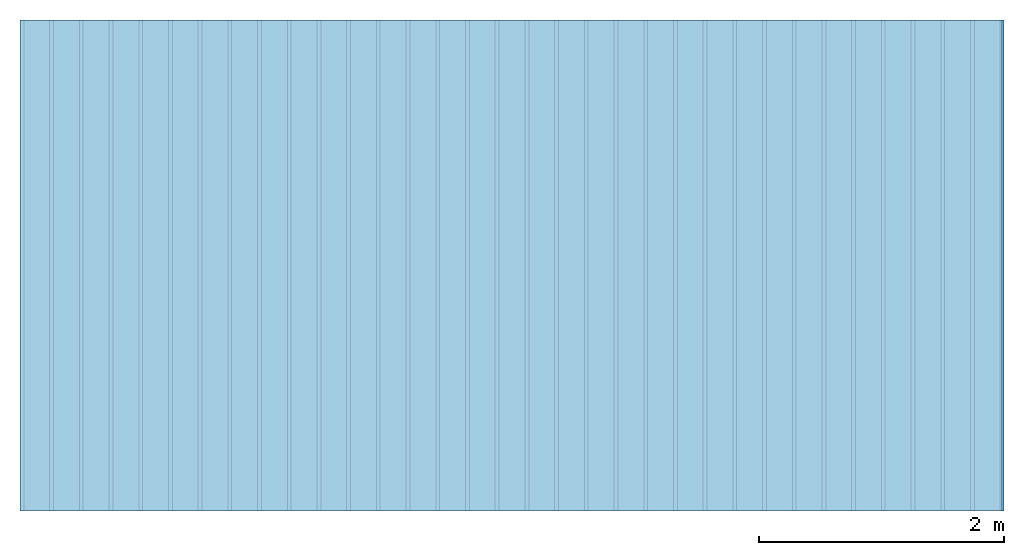
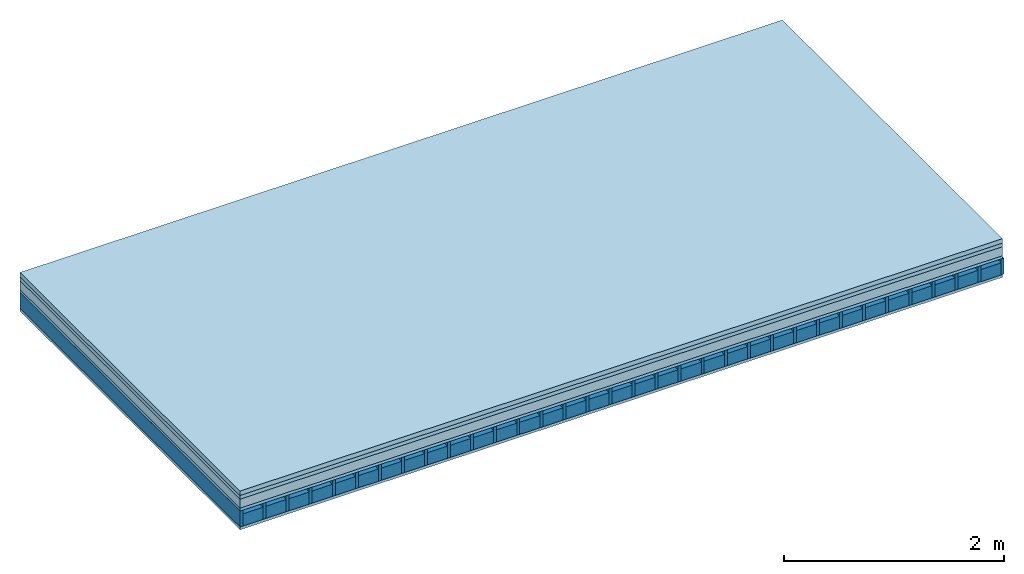
# One storey: 5 plates, 2 members, 1 element without a shape of its own.
"""IFC4 building model written with IfcOpenShell, lengths in metres."""

from ifc_helpers import new_model, si_unit, derived_unit, direction, frame, frame_2d, origin, origin_with_axes, place, context, project, spatial, rectangle, extrude, material, layer, layer_set, type_object, element, aggregate, save


model = new_model("IFC4")

# Units and contexts
plan_context = context("Plan", 3, precision=1e-05, world=origin(), true_north=direction((0.0, 1.0)))
model_context = context("Model", 3, precision=1e-05, world=origin(), true_north=direction((0.0, 1.0)))
ifc_project = project(units=[si_unit("LENGTHUNIT", "METRE"), derived_unit("SOUNDPRESSUREUNIT", [(si_unit("PRESSUREUNIT", "PASCAL", prefix="MICRO"), 0)]), si_unit("ENERGYUNIT", "JOULE", prefix="MEGA"), si_unit("MASSUNIT", "GRAM", prefix="KILO"), derived_unit("THERMALTRANSMITTANCEUNIT", [(si_unit("POWERUNIT", "WATT"), 1), (si_unit("AREAUNIT", "SQUARE_METRE"), -1), (si_unit("THERMODYNAMICTEMPERATUREUNIT", "KELVIN"), -1)]), derived_unit("AREADENSITYUNIT", [(si_unit("MASSUNIT", "GRAM", prefix="KILO"), 1), (si_unit("AREAUNIT", "SQUARE_METRE"), -1)]), derived_unit("USERDEFINED", [(si_unit("ENERGYUNIT", "JOULE", prefix="MEGA"), 1), (si_unit("AREAUNIT", "SQUARE_METRE"), -1)])], contexts=[plan_context, model_context])

# Site, building, storey
site = spatial("IfcSite", under=ifc_project)
building_placement = place(None, origin())
building = spatial("IfcBuilding", under=site, at=building_placement)
storey_placement = place(building_placement, origin())
storey = spatial("IfcBuildingStorey", under=building, at=storey_placement)

# Slab, members, plates
ifc_material_1 = material(Name="Cement screed", Category="04.006")
ifc_layer_1 = layer(ifc_material_1, 0.05, Name="On-material")
ifc_material_2 = material(Name="EP1, 40/35mm")
ifc_layer_2 = layer(ifc_material_2, 0.04, Name="Impact sound insulation")
ifc_material_3 = material(Category="03.011")
ifc_layer_3 = layer(ifc_material_3, 0.1, Name="on Supporting structure")
ifc_material_4 = material(Name="surface element sheathing above")
ifc_layer_4 = layer(ifc_material_4, 0.031, Name="Sub-floor")
ifc_layer_5 = layer(None, 0.178, Name="Supporting structure")
ifc_material_5 = material(Name="surface element sheathing below")
ifc_layer_6 = layer(ifc_material_5, 0.031, Name="Lower layer 1")
ifc_layer_set = layer_set([ifc_layer_1, ifc_layer_2, ifc_layer_3, ifc_layer_4, ifc_layer_5, ifc_layer_6])
slab_type = type_object("IfcSlabType", Name="A1467", PredefinedType="NOTDEFINED", material=ifc_layer_set)
slab_placement = place(None, frame((0.0, 0.0, 0.0), z_axis=(0.0, 0.0, -1.0), x_axis=(1.0, 0.0, 0.0)))
slab = element("IfcSlab", 1, at=slab_placement, inside=storey, type_object=slab_type, material=ifc_layer_set, Name="Slab #1")
ifc_material_6 = material(Name="surface element LFE 12")
member_1_placement = place(slab_placement, origin())
member_1 = element("IfcMember", 2, at=member_1_placement, material=ifc_material_6, Name="Supporting structure", context=plan_context, shape_type="SweptSolid", body=[
    extrude(rectangle(XDim=0.031, YDim=0.178, at=frame_2d((0.0155, 0.089), x_axis=(1.0, 0.0))), frame((0.0, 4.0, 0.221), z_axis=(0.0, -1.0, 0.0), x_axis=(1.0, 0.0, 0.0)), (0.0, 0.0, 1.0), 4.0),
    extrude(rectangle(XDim=0.031, YDim=0.178, at=frame_2d((0.0155, 0.089), x_axis=(1.0, 0.0))), frame((0.242, 4.0, 0.221), z_axis=(0.0, -1.0, 0.0), x_axis=(1.0, 0.0, 0.0)), (0.0, 0.0, 1.0), 4.0),
    extrude(rectangle(XDim=0.031, YDim=0.178, at=frame_2d((0.0155, 0.089), x_axis=(1.0, 0.0))), frame((0.484, 4.0, 0.221), z_axis=(0.0, -1.0, 0.0), x_axis=(1.0, 0.0, 0.0)), (0.0, 0.0, 1.0), 4.0),
    extrude(rectangle(XDim=0.031, YDim=0.178, at=frame_2d((0.0155, 0.089), x_axis=(1.0, 0.0))), frame((0.726, 4.0, 0.221), z_axis=(0.0, -1.0, 0.0), x_axis=(1.0, 0.0, 0.0)), (0.0, 0.0, 1.0), 4.0),
    extrude(rectangle(XDim=0.031, YDim=0.178, at=frame_2d((0.0155, 0.089), x_axis=(1.0, 0.0))), frame((0.968, 4.0, 0.221), z_axis=(0.0, -1.0, 0.0), x_axis=(1.0, 0.0, 0.0)), (0.0, 0.0, 1.0), 4.0),
    extrude(rectangle(XDim=0.031, YDim=0.178, at=frame_2d((0.0155, 0.089), x_axis=(1.0, 0.0))), frame((1.21, 4.0, 0.221), z_axis=(0.0, -1.0, 0.0), x_axis=(1.0, 0.0, 0.0)), (0.0, 0.0, 1.0), 4.0),
    extrude(rectangle(XDim=0.031, YDim=0.178, at=frame_2d((0.0155, 0.089), x_axis=(1.0, 0.0))), frame((1.452, 4.0, 0.221), z_axis=(0.0, -1.0, 0.0), x_axis=(1.0, 0.0, 0.0)), (0.0, 0.0, 1.0), 4.0),
    extrude(rectangle(XDim=0.031, YDim=0.178, at=frame_2d((0.0155, 0.089), x_axis=(1.0, 0.0))), frame((1.694, 4.0, 0.221), z_axis=(0.0, -1.0, 0.0), x_axis=(1.0, 0.0, 0.0)), (0.0, 0.0, 1.0), 4.0),
    extrude(rectangle(XDim=0.031, YDim=0.178, at=frame_2d((0.0155, 0.089), x_axis=(1.0, 0.0))), frame((1.936, 4.0, 0.221), z_axis=(0.0, -1.0, 0.0), x_axis=(1.0, 0.0, 0.0)), (0.0, 0.0, 1.0), 4.0),
    extrude(rectangle(XDim=0.031, YDim=0.178, at=frame_2d((0.0155, 0.089), x_axis=(1.0, 0.0))), frame((2.178, 4.0, 0.221), z_axis=(0.0, -1.0, 0.0), x_axis=(1.0, 0.0, 0.0)), (0.0, 0.0, 1.0), 4.0),
    extrude(rectangle(XDim=0.031, YDim=0.178, at=frame_2d((0.0155, 0.089), x_axis=(1.0, 0.0))), frame((2.42, 4.0, 0.221), z_axis=(0.0, -1.0, 0.0), x_axis=(1.0, 0.0, 0.0)), (0.0, 0.0, 1.0), 4.0),
    extrude(rectangle(XDim=0.031, YDim=0.178, at=frame_2d((0.0155, 0.089), x_axis=(1.0, 0.0))), frame((2.662, 4.0, 0.221), z_axis=(0.0, -1.0, 0.0), x_axis=(1.0, 0.0, 0.0)), (0.0, 0.0, 1.0), 4.0),
    extrude(rectangle(XDim=0.031, YDim=0.178, at=frame_2d((0.0155, 0.089), x_axis=(1.0, 0.0))), frame((2.904, 4.0, 0.221), z_axis=(0.0, -1.0, 0.0), x_axis=(1.0, 0.0, 0.0)), (0.0, 0.0, 1.0), 4.0),
    extrude(rectangle(XDim=0.031, YDim=0.178, at=frame_2d((0.0155, 0.089), x_axis=(1.0, 0.0))), frame((3.146, 4.0, 0.221), z_axis=(0.0, -1.0, 0.0), x_axis=(1.0, 0.0, 0.0)), (0.0, 0.0, 1.0), 4.0),
    extrude(rectangle(XDim=0.031, YDim=0.178, at=frame_2d((0.0155, 0.089), x_axis=(1.0, 0.0))), frame((3.388, 4.0, 0.221), z_axis=(0.0, -1.0, 0.0), x_axis=(1.0, 0.0, 0.0)), (0.0, 0.0, 1.0), 4.0),
    extrude(rectangle(XDim=0.031, YDim=0.178, at=frame_2d((0.0155, 0.089), x_axis=(1.0, 0.0))), frame((3.63, 4.0, 0.221), z_axis=(0.0, -1.0, 0.0), x_axis=(1.0, 0.0, 0.0)), (0.0, 0.0, 1.0), 4.0),
    extrude(rectangle(XDim=0.031, YDim=0.178, at=frame_2d((0.0155, 0.089), x_axis=(1.0, 0.0))), frame((3.872, 4.0, 0.221), z_axis=(0.0, -1.0, 0.0), x_axis=(1.0, 0.0, 0.0)), (0.0, 0.0, 1.0), 4.0),
    extrude(rectangle(XDim=0.031, YDim=0.178, at=frame_2d((0.0155, 0.089), x_axis=(1.0, 0.0))), frame((4.114, 4.0, 0.221), z_axis=(0.0, -1.0, 0.0), x_axis=(1.0, 0.0, 0.0)), (0.0, 0.0, 1.0), 4.0),
    extrude(rectangle(XDim=0.031, YDim=0.178, at=frame_2d((0.0155, 0.089), x_axis=(1.0, 0.0))), frame((4.356, 4.0, 0.221), z_axis=(0.0, -1.0, 0.0), x_axis=(1.0, 0.0, 0.0)), (0.0, 0.0, 1.0), 4.0),
    extrude(rectangle(XDim=0.031, YDim=0.178, at=frame_2d((0.0155, 0.089), x_axis=(1.0, 0.0))), frame((4.598, 4.0, 0.221), z_axis=(0.0, -1.0, 0.0), x_axis=(1.0, 0.0, 0.0)), (0.0, 0.0, 1.0), 4.0),
    extrude(rectangle(XDim=0.031, YDim=0.178, at=frame_2d((0.0155, 0.089), x_axis=(1.0, 0.0))), frame((4.84, 4.0, 0.221), z_axis=(0.0, -1.0, 0.0), x_axis=(1.0, 0.0, 0.0)), (0.0, 0.0, 1.0), 4.0),
    extrude(rectangle(XDim=0.031, YDim=0.178, at=frame_2d((0.0155, 0.089), x_axis=(1.0, 0.0))), frame((5.082, 4.0, 0.221), z_axis=(0.0, -1.0, 0.0), x_axis=(1.0, 0.0, 0.0)), (0.0, 0.0, 1.0), 4.0),
    extrude(rectangle(XDim=0.031, YDim=0.178, at=frame_2d((0.0155, 0.089), x_axis=(1.0, 0.0))), frame((5.324, 4.0, 0.221), z_axis=(0.0, -1.0, 0.0), x_axis=(1.0, 0.0, 0.0)), (0.0, 0.0, 1.0), 4.0),
    extrude(rectangle(XDim=0.031, YDim=0.178, at=frame_2d((0.0155, 0.089), x_axis=(1.0, 0.0))), frame((5.566, 4.0, 0.221), z_axis=(0.0, -1.0, 0.0), x_axis=(1.0, 0.0, 0.0)), (0.0, 0.0, 1.0), 4.0),
    extrude(rectangle(XDim=0.031, YDim=0.178, at=frame_2d((0.0155, 0.089), x_axis=(1.0, 0.0))), frame((5.808, 4.0, 0.221), z_axis=(0.0, -1.0, 0.0), x_axis=(1.0, 0.0, 0.0)), (0.0, 0.0, 1.0), 4.0),
    extrude(rectangle(XDim=0.031, YDim=0.178, at=frame_2d((0.0155, 0.089), x_axis=(1.0, 0.0))), frame((6.05, 4.0, 0.221), z_axis=(0.0, -1.0, 0.0), x_axis=(1.0, 0.0, 0.0)), (0.0, 0.0, 1.0), 4.0),
    extrude(rectangle(XDim=0.031, YDim=0.178, at=frame_2d((0.0155, 0.089), x_axis=(1.0, 0.0))), frame((6.292, 4.0, 0.221), z_axis=(0.0, -1.0, 0.0), x_axis=(1.0, 0.0, 0.0)), (0.0, 0.0, 1.0), 4.0),
    extrude(rectangle(XDim=0.031, YDim=0.178, at=frame_2d((0.0155, 0.089), x_axis=(1.0, 0.0))), frame((6.534, 4.0, 0.221), z_axis=(0.0, -1.0, 0.0), x_axis=(1.0, 0.0, 0.0)), (0.0, 0.0, 1.0), 4.0),
    extrude(rectangle(XDim=0.031, YDim=0.178, at=frame_2d((0.0155, 0.089), x_axis=(1.0, 0.0))), frame((6.776, 4.0, 0.221), z_axis=(0.0, -1.0, 0.0), x_axis=(1.0, 0.0, 0.0)), (0.0, 0.0, 1.0), 4.0),
    extrude(rectangle(XDim=0.031, YDim=0.178, at=frame_2d((0.0155, 0.089), x_axis=(1.0, 0.0))), frame((7.018, 4.0, 0.221), z_axis=(0.0, -1.0, 0.0), x_axis=(1.0, 0.0, 0.0)), (0.0, 0.0, 1.0), 4.0),
    extrude(rectangle(XDim=0.031, YDim=0.178, at=frame_2d((0.0155, 0.089), x_axis=(1.0, 0.0))), frame((7.26, 4.0, 0.221), z_axis=(0.0, -1.0, 0.0), x_axis=(1.0, 0.0, 0.0)), (0.0, 0.0, 1.0), 4.0),
    extrude(rectangle(XDim=0.031, YDim=0.178, at=frame_2d((0.0155, 0.089), x_axis=(1.0, 0.0))), frame((7.502, 4.0, 0.221), z_axis=(0.0, -1.0, 0.0), x_axis=(1.0, 0.0, 0.0)), (0.0, 0.0, 1.0), 4.0),
    extrude(rectangle(XDim=0.031, YDim=0.178, at=frame_2d((0.0155, 0.089), x_axis=(1.0, 0.0))), frame((7.744, 4.0, 0.221), z_axis=(0.0, -1.0, 0.0), x_axis=(1.0, 0.0, 0.0)), (0.0, 0.0, 1.0), 4.0),
    extrude(rectangle(XDim=0.031, YDim=0.178, at=frame_2d((0.0155, 0.089), x_axis=(1.0, 0.0))), frame((7.986, 4.0, 0.221), z_axis=(0.0, -1.0, 0.0), x_axis=(1.0, 0.0, 0.0)), (0.0, 0.0, 1.0), 4.0),
])
ifc_material_7 = material(Name="Damper LFE 12")
member_2_placement = place(slab_placement, origin())
member_2 = element("IfcMember", 3, at=member_2_placement, material=ifc_material_7, Name="in supporting structure", context=plan_context, shape_type="SweptSolid", body=[
    extrude(rectangle(XDim=0.211, YDim=0.135, at=frame_2d((0.1055, 0.0675), x_axis=(1.0, 0.0))), frame((0.031, 4.0, 0.264), z_axis=(0.0, -1.0, 0.0), x_axis=(1.0, 0.0, 0.0)), (0.0, 0.0, 1.0), 4.0),
    extrude(rectangle(XDim=0.211, YDim=0.135, at=frame_2d((0.1055, 0.0675), x_axis=(1.0, 0.0))), frame((0.273, 4.0, 0.264), z_axis=(0.0, -1.0, 0.0), x_axis=(1.0, 0.0, 0.0)), (0.0, 0.0, 1.0), 4.0),
    extrude(rectangle(XDim=0.211, YDim=0.135, at=frame_2d((0.1055, 0.0675), x_axis=(1.0, 0.0))), frame((0.515, 4.0, 0.264), z_axis=(0.0, -1.0, 0.0), x_axis=(1.0, 0.0, 0.0)), (0.0, 0.0, 1.0), 4.0),
    extrude(rectangle(XDim=0.211, YDim=0.135, at=frame_2d((0.1055, 0.0675), x_axis=(1.0, 0.0))), frame((0.757, 4.0, 0.264), z_axis=(0.0, -1.0, 0.0), x_axis=(1.0, 0.0, 0.0)), (0.0, 0.0, 1.0), 4.0),
    extrude(rectangle(XDim=0.211, YDim=0.135, at=frame_2d((0.1055, 0.0675), x_axis=(1.0, 0.0))), frame((0.999, 4.0, 0.264), z_axis=(0.0, -1.0, 0.0), x_axis=(1.0, 0.0, 0.0)), (0.0, 0.0, 1.0), 4.0),
    extrude(rectangle(XDim=0.211, YDim=0.135, at=frame_2d((0.1055, 0.0675), x_axis=(1.0, 0.0))), frame((1.241, 4.0, 0.264), z_axis=(0.0, -1.0, 0.0), x_axis=(1.0, 0.0, 0.0)), (0.0, 0.0, 1.0), 4.0),
    extrude(rectangle(XDim=0.211, YDim=0.135, at=frame_2d((0.1055, 0.0675), x_axis=(1.0, 0.0))), frame((1.483, 4.0, 0.264), z_axis=(0.0, -1.0, 0.0), x_axis=(1.0, 0.0, 0.0)), (0.0, 0.0, 1.0), 4.0),
    extrude(rectangle(XDim=0.211, YDim=0.135, at=frame_2d((0.1055, 0.0675), x_axis=(1.0, 0.0))), frame((1.725, 4.0, 0.264), z_axis=(0.0, -1.0, 0.0), x_axis=(1.0, 0.0, 0.0)), (0.0, 0.0, 1.0), 4.0),
    extrude(rectangle(XDim=0.211, YDim=0.135, at=frame_2d((0.1055, 0.0675), x_axis=(1.0, 0.0))), frame((1.967, 4.0, 0.264), z_axis=(0.0, -1.0, 0.0), x_axis=(1.0, 0.0, 0.0)), (0.0, 0.0, 1.0), 4.0),
    extrude(rectangle(XDim=0.211, YDim=0.135, at=frame_2d((0.1055, 0.0675), x_axis=(1.0, 0.0))), frame((2.209, 4.0, 0.264), z_axis=(0.0, -1.0, 0.0), x_axis=(1.0, 0.0, 0.0)), (0.0, 0.0, 1.0), 4.0),
    extrude(rectangle(XDim=0.211, YDim=0.135, at=frame_2d((0.1055, 0.0675), x_axis=(1.0, 0.0))), frame((2.451, 4.0, 0.264), z_axis=(0.0, -1.0, 0.0), x_axis=(1.0, 0.0, 0.0)), (0.0, 0.0, 1.0), 4.0),
    extrude(rectangle(XDim=0.211, YDim=0.135, at=frame_2d((0.1055, 0.0675), x_axis=(1.0, 0.0))), frame((2.693, 4.0, 0.264), z_axis=(0.0, -1.0, 0.0), x_axis=(1.0, 0.0, 0.0)), (0.0, 0.0, 1.0), 4.0),
    extrude(rectangle(XDim=0.211, YDim=0.135, at=frame_2d((0.1055, 0.0675), x_axis=(1.0, 0.0))), frame((2.935, 4.0, 0.264), z_axis=(0.0, -1.0, 0.0), x_axis=(1.0, 0.0, 0.0)), (0.0, 0.0, 1.0), 4.0),
    extrude(rectangle(XDim=0.211, YDim=0.135, at=frame_2d((0.1055, 0.0675), x_axis=(1.0, 0.0))), frame((3.177, 4.0, 0.264), z_axis=(0.0, -1.0, 0.0), x_axis=(1.0, 0.0, 0.0)), (0.0, 0.0, 1.0), 4.0),
    extrude(rectangle(XDim=0.211, YDim=0.135, at=frame_2d((0.1055, 0.0675), x_axis=(1.0, 0.0))), frame((3.419, 4.0, 0.264), z_axis=(0.0, -1.0, 0.0), x_axis=(1.0, 0.0, 0.0)), (0.0, 0.0, 1.0), 4.0),
    extrude(rectangle(XDim=0.211, YDim=0.135, at=frame_2d((0.1055, 0.0675), x_axis=(1.0, 0.0))), frame((3.661, 4.0, 0.264), z_axis=(0.0, -1.0, 0.0), x_axis=(1.0, 0.0, 0.0)), (0.0, 0.0, 1.0), 4.0),
    extrude(rectangle(XDim=0.211, YDim=0.135, at=frame_2d((0.1055, 0.0675), x_axis=(1.0, 0.0))), frame((3.903, 4.0, 0.264), z_axis=(0.0, -1.0, 0.0), x_axis=(1.0, 0.0, 0.0)), (0.0, 0.0, 1.0), 4.0),
    extrude(rectangle(XDim=0.211, YDim=0.135, at=frame_2d((0.1055, 0.0675), x_axis=(1.0, 0.0))), frame((4.145, 4.0, 0.264), z_axis=(0.0, -1.0, 0.0), x_axis=(1.0, 0.0, 0.0)), (0.0, 0.0, 1.0), 4.0),
    extrude(rectangle(XDim=0.211, YDim=0.135, at=frame_2d((0.1055, 0.0675), x_axis=(1.0, 0.0))), frame((4.387, 4.0, 0.264), z_axis=(0.0, -1.0, 0.0), x_axis=(1.0, 0.0, 0.0)), (0.0, 0.0, 1.0), 4.0),
    extrude(rectangle(XDim=0.211, YDim=0.135, at=frame_2d((0.1055, 0.0675), x_axis=(1.0, 0.0))), frame((4.629, 4.0, 0.264), z_axis=(0.0, -1.0, 0.0), x_axis=(1.0, 0.0, 0.0)), (0.0, 0.0, 1.0), 4.0),
    extrude(rectangle(XDim=0.211, YDim=0.135, at=frame_2d((0.1055, 0.0675), x_axis=(1.0, 0.0))), frame((4.871, 4.0, 0.264), z_axis=(0.0, -1.0, 0.0), x_axis=(1.0, 0.0, 0.0)), (0.0, 0.0, 1.0), 4.0),
    extrude(rectangle(XDim=0.211, YDim=0.135, at=frame_2d((0.1055, 0.0675), x_axis=(1.0, 0.0))), frame((5.113, 4.0, 0.264), z_axis=(0.0, -1.0, 0.0), x_axis=(1.0, 0.0, 0.0)), (0.0, 0.0, 1.0), 4.0),
    extrude(rectangle(XDim=0.211, YDim=0.135, at=frame_2d((0.1055, 0.0675), x_axis=(1.0, 0.0))), frame((5.355, 4.0, 0.264), z_axis=(0.0, -1.0, 0.0), x_axis=(1.0, 0.0, 0.0)), (0.0, 0.0, 1.0), 4.0),
    extrude(rectangle(XDim=0.211, YDim=0.135, at=frame_2d((0.1055, 0.0675), x_axis=(1.0, 0.0))), frame((5.597, 4.0, 0.264), z_axis=(0.0, -1.0, 0.0), x_axis=(1.0, 0.0, 0.0)), (0.0, 0.0, 1.0), 4.0),
    extrude(rectangle(XDim=0.211, YDim=0.135, at=frame_2d((0.1055, 0.0675), x_axis=(1.0, 0.0))), frame((5.839, 4.0, 0.264), z_axis=(0.0, -1.0, 0.0), x_axis=(1.0, 0.0, 0.0)), (0.0, 0.0, 1.0), 4.0),
    extrude(rectangle(XDim=0.211, YDim=0.135, at=frame_2d((0.1055, 0.0675), x_axis=(1.0, 0.0))), frame((6.081, 4.0, 0.264), z_axis=(0.0, -1.0, 0.0), x_axis=(1.0, 0.0, 0.0)), (0.0, 0.0, 1.0), 4.0),
    extrude(rectangle(XDim=0.211, YDim=0.135, at=frame_2d((0.1055, 0.0675), x_axis=(1.0, 0.0))), frame((6.323, 4.0, 0.264), z_axis=(0.0, -1.0, 0.0), x_axis=(1.0, 0.0, 0.0)), (0.0, 0.0, 1.0), 4.0),
    extrude(rectangle(XDim=0.211, YDim=0.135, at=frame_2d((0.1055, 0.0675), x_axis=(1.0, 0.0))), frame((6.565, 4.0, 0.264), z_axis=(0.0, -1.0, 0.0), x_axis=(1.0, 0.0, 0.0)), (0.0, 0.0, 1.0), 4.0),
    extrude(rectangle(XDim=0.211, YDim=0.135, at=frame_2d((0.1055, 0.0675), x_axis=(1.0, 0.0))), frame((6.807, 4.0, 0.264), z_axis=(0.0, -1.0, 0.0), x_axis=(1.0, 0.0, 0.0)), (0.0, 0.0, 1.0), 4.0),
    extrude(rectangle(XDim=0.211, YDim=0.135, at=frame_2d((0.1055, 0.0675), x_axis=(1.0, 0.0))), frame((7.049, 4.0, 0.264), z_axis=(0.0, -1.0, 0.0), x_axis=(1.0, 0.0, 0.0)), (0.0, 0.0, 1.0), 4.0),
    extrude(rectangle(XDim=0.211, YDim=0.135, at=frame_2d((0.1055, 0.0675), x_axis=(1.0, 0.0))), frame((7.291, 4.0, 0.264), z_axis=(0.0, -1.0, 0.0), x_axis=(1.0, 0.0, 0.0)), (0.0, 0.0, 1.0), 4.0),
    extrude(rectangle(XDim=0.211, YDim=0.135, at=frame_2d((0.1055, 0.0675), x_axis=(1.0, 0.0))), frame((7.533, 4.0, 0.264), z_axis=(0.0, -1.0, 0.0), x_axis=(1.0, 0.0, 0.0)), (0.0, 0.0, 1.0), 4.0),
    extrude(rectangle(XDim=0.211, YDim=0.135, at=frame_2d((0.1055, 0.0675), x_axis=(1.0, 0.0))), frame((7.775, 4.0, 0.264), z_axis=(0.0, -1.0, 0.0), x_axis=(1.0, 0.0, 0.0)), (0.0, 0.0, 1.0), 4.0),
])
plate_1_placement = place(slab_placement, origin())
plate_1 = element("IfcPlate", 4, at=plate_1_placement, material=ifc_material_1, Name="On-material", context=plan_context, shape_type="SweptSolid", body=[
    extrude(rectangle(XDim=8.0, YDim=4.0, at=frame_2d((4.0, 2.0), x_axis=(1.0, 0.0))), origin_with_axes(), (0.0, 0.0, 1.0), 0.05),
])
plate_2_placement = place(slab_placement, origin())
plate_2 = element("IfcPlate", 5, at=plate_2_placement, material=ifc_material_2, Name="Impact sound insulation", context=plan_context, shape_type="SweptSolid", body=[
    extrude(rectangle(XDim=8.0, YDim=4.0, at=frame_2d((4.0, 2.0), x_axis=(1.0, 0.0))), frame((0.0, 0.0, 0.05), z_axis=(0.0, 0.0, 1.0), x_axis=(1.0, 0.0, 0.0)), (0.0, 0.0, 1.0), 0.04),
])
plate_3_placement = place(slab_placement, origin())
plate_3 = element("IfcPlate", 6, at=plate_3_placement, material=ifc_material_3, Name="on Supporting structure", context=plan_context, shape_type="SweptSolid", body=[
    extrude(rectangle(XDim=8.0, YDim=4.0, at=frame_2d((4.0, 2.0), x_axis=(1.0, 0.0))), frame((0.0, 0.0, 0.09), z_axis=(0.0, 0.0, 1.0), x_axis=(1.0, 0.0, 0.0)), (0.0, 0.0, 1.0), 0.1),
])
plate_4_placement = place(slab_placement, origin())
plate_4 = element("IfcPlate", 7, at=plate_4_placement, material=ifc_material_4, Name="Sub-floor", context=plan_context, shape_type="SweptSolid", body=[
    extrude(rectangle(XDim=8.0, YDim=4.0, at=frame_2d((4.0, 2.0), x_axis=(1.0, 0.0))), frame((0.0, 0.0, 0.19), z_axis=(0.0, 0.0, 1.0), x_axis=(1.0, 0.0, 0.0)), (0.0, 0.0, 1.0), 0.031),
])
plate_5_placement = place(slab_placement, origin())
plate_5 = element("IfcPlate", 8, at=plate_5_placement, material=ifc_material_5, Name="Lower layer 1", context=plan_context, shape_type="SweptSolid", body=[
    extrude(rectangle(XDim=8.0, YDim=4.0, at=frame_2d((4.0, 2.0), x_axis=(1.0, 0.0))), frame((0.0, 0.0, 0.399), z_axis=(0.0, 0.0, 1.0), x_axis=(1.0, 0.0, 0.0)), (0.0, 0.0, 1.0), 0.031),
])
aggregate(slab, [plate_1, plate_2, plate_3, plate_4, member_1, member_2, plate_5])

save(model, "model.ifc")
